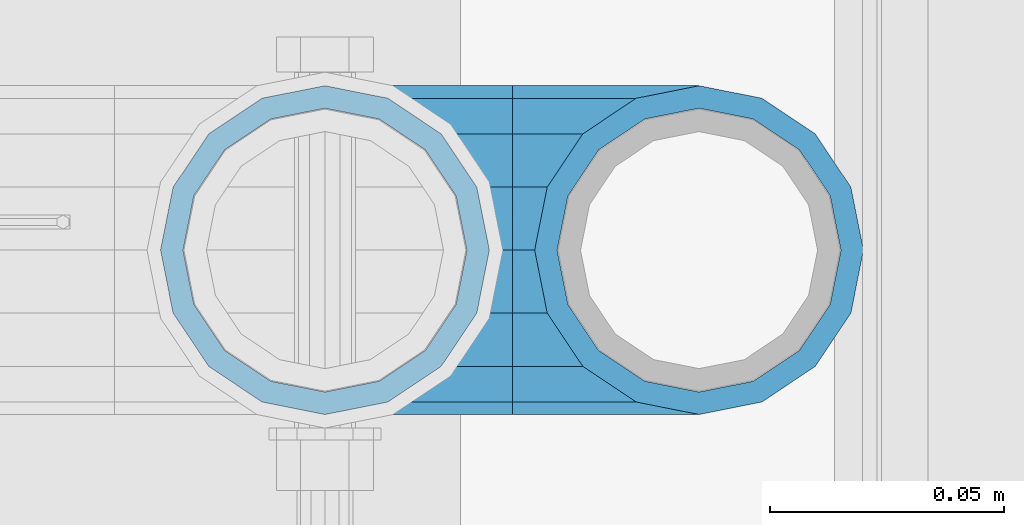
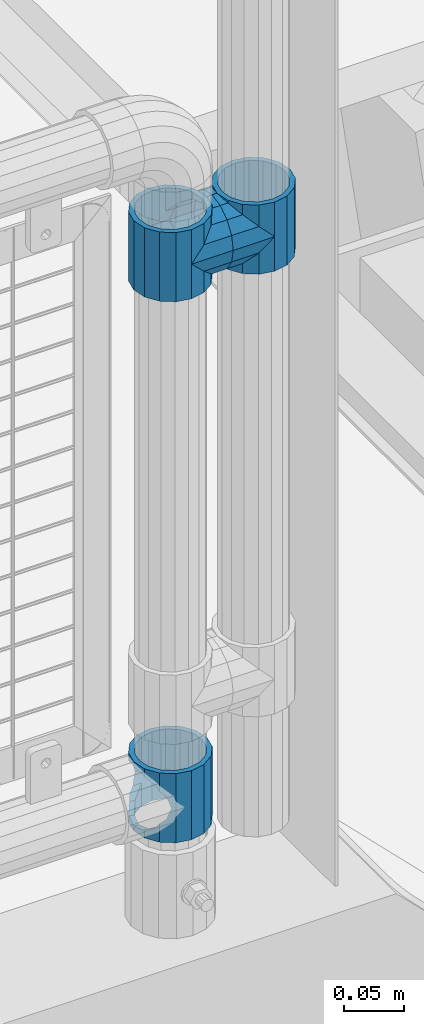
# One storey, part 129 of 193: 5 beams.
"""IFC2X3 building model written with IfcOpenShell, lengths in millimetres."""

from ifc_helpers import new_model, si_unit, frame, origin_with_axes, place, context, subcontext, project, spatial, faceted_brep, material, type_object, element, save


model = new_model("IFC2X3")

# Units and contexts
model_context = context("Model", 3, precision=1e-05, world=origin_with_axes())
body_context = subcontext(model_context, "Body", "Model", "MODEL_VIEW")
ifc_project = project(units=[si_unit("LENGTHUNIT", "METRE", prefix="MILLI"), si_unit("AREAUNIT", "SQUARE_METRE"), si_unit("VOLUMEUNIT", "CUBIC_METRE"), si_unit("MASSUNIT", "GRAM", prefix="KILO"), si_unit("TIMEUNIT", "SECOND"), si_unit("PLANEANGLEUNIT", "RADIAN"), si_unit("SOLIDANGLEUNIT", "STERADIAN"), si_unit("THERMODYNAMICTEMPERATUREUNIT", "DEGREE_CELSIUS"), si_unit("LUMINOUSINTENSITYUNIT", "LUMEN")], contexts=[model_context])

# Site, building, storey
site_placement = place(None, origin_with_axes())
site = spatial("IfcSite", under=ifc_project, at=site_placement, CompositionType="ELEMENT")
building_placement = place(site_placement, origin_with_axes())
building = spatial("IfcBuilding", under=site, at=building_placement, Name="Standard", CompositionType="ELEMENT")
storey_placement = place(building_placement, origin_with_axes())
storey = spatial("IfcBuildingStorey", under=building, at=storey_placement, Name="Undefined", CompositionType="ELEMENT", Elevation=0.0)

# Beams
ifc_material = material(Name="Misc_Undefined")
beam_type = type_object("IfcBeamType", PredefinedType="NOTDEFINED")
beam_1_placement = place(storey_placement, frame((-29019.0, 28664.5, 333.820000000001), z_axis=(1.0, 0.0, 0.0), x_axis=(0.0, 0.0, -1.0)))
element("IfcBeam", 1, at=beam_1_placement, inside=storey, type_object=beam_type, material=ifc_material, context=body_context, shape_type="Brep", body=[
    faceted_brep([(46.7644421722801, 28.0397438117179, -11.614442172282), (46.7644421722801, 28.0397438117179, -20.0882031229849), (51.5310424080006, 24.8548033587067, -24.8548033587067), (56.6106908090114, 21.46069080901, -27.1226768591041), (56.6106908090114, 21.46069080901, -21.46069080901), (61.9623795176744, 13.4513226476338, -32.4743655677703), (63.1897438117172, 11.614442172282, -32.8397438117245), (63.1897438117172, 11.614442172282, -28.0397438117179), (65.4999999999997, 0.0, -35.1500000000015), (65.4999999999997, 0.0, -30.3499999999985), (63.1897438117172, -11.614442172282, -32.8397438117172), (63.1897438117172, -11.614442172282, -28.0397438117179), (61.9623795176767, -13.4513226476338, -32.4743655677703), (56.6106908090114, -21.46069080901, -27.1226768591114), (56.6106908090114, -21.46069080901, -21.46069080901), (51.5310424080006, -24.8548033587067, -24.8548033587067), (46.7644421722801, -28.0397438117179, -20.0882031229812), (46.7644421722801, -28.0397438117179, -11.614442172282), (35.1499999999996, -30.3499999999985, -16.6306603983721), (35.1500000000015, -30.35, 0.0), (23.5355578277191, -28.0397438117179, -20.0882031229812), (23.5355578277191, -28.0397438117179, -11.614442172282), (18.7689575919921, -24.8548033587067, -24.8548033587067), (13.6893091909879, -21.46069080901, -27.1226768591114), (13.6893091909879, -21.46069080901, -21.46069080901), (8.33762048232484, -13.4513226476338, -32.4743655677703), (7.11025618828211, -11.614442172282, -32.8397438117172), (7.11025618828211, -11.614442172282, -28.0397438117179), (4.79999999999961, 0.0, -35.1500000000015), (4.79999999999961, 0.0, -30.3499999999985), (7.11025618828211, 11.614442172282, -32.8397438117245), (7.11025618828211, 11.614442172282, -28.0397438117179), (8.33762048232262, 13.4513226476338, -32.4743655677703), (13.6893091909879, 21.46069080901, -27.1226768591041), (13.6893091909879, 21.46069080901, -21.46069080901), (18.7689575919987, 24.8548033587067, -24.8548033587067), (23.5355578277192, 28.0397438117179, -20.0882031229849), (23.5355578277192, 28.0397438117179, -11.614442172282), (35.1499999999996, 30.3499999999985, -16.6306603983685), (35.1500000000015, 30.35, 0.0), (0.0, 32.4743655677703, -13.4513226476338), (0.0, 35.1500000000015, 0.0), (70.2999999999993, 35.1500000000015, 0.0), (70.2999999999993, 32.4743655677703, -13.4513226476338), (0.0, 32.4743655677703, 13.4513226476338), (70.2999999999993, 32.4743655677703, 13.4513226476338), (0.0, 24.8548033587067, 24.8548033587067), (70.2999999999993, 24.8548033587067, 24.8548033587067), (0.0, 13.4513226476338, 32.4743655677703), (70.2999999999993, 13.4513226476338, 32.4743655677703), (0.0, 0.0, 35.1500000000015), (70.2999999999993, 0.0, 35.1500000000015), (0.0, -13.4513226476338, 32.4743655677703), (70.2999999999993, -13.4513226476338, 32.4743655677703), (0.0, -24.8548033587067, 24.8548033587067), (70.2999999999993, -24.8548033587067, 24.8548033587067), (0.0, -32.4743655677703, 13.4513226476338), (70.2999999999993, -32.4743655677703, 13.4513226476338), (0.0, -35.1500000000015, 0.0), (70.2999999999993, -35.1500000000015, 0.0), (70.2999999999993, -30.3499999999985, 0.0), (70.2999999999993, -28.0397438117179, -11.614442172282), (70.2999999999993, -21.46069080901, -21.46069080901), (70.2999999999993, -11.614442172282, -28.0397438117179), (70.2999999999993, 0.0, -30.3499999999985), (70.2999999999993, 11.614442172282, -28.0397438117179), (70.2999999999993, 21.46069080901, -21.46069080901), (70.2999999999993, 28.0397438117179, -11.614442172282), (0.0, -28.0397438117179, -11.614442172282), (0.0, -30.3499999999985, 0.0), (0.0, -21.46069080901, -21.46069080901), (0.0, -11.614442172282, -28.0397438117179), (0.0, 0.0, -30.3499999999985), (0.0, 11.614442172282, -28.0397438117179), (0.0, 21.46069080901, -21.46069080901), (0.0, 28.0397438117179, -11.614442172282), (0.0, 30.3499999999985, 0.0), (70.2999999999993, 30.3499999999985, 0.0), (0.0, 28.0397438117179, 11.614442172282), (70.2999999999993, 28.0397438117179, 11.614442172282), (0.0, 21.46069080901, 21.46069080901), (70.2999999999993, 21.46069080901, 21.46069080901), (0.0, 11.614442172282, 28.0397438117179), (70.2999999999993, 11.614442172282, 28.0397438117179), (0.0, 0.0, 30.3499999999985), (70.2999999999993, 0.0, 30.3499999999985), (0.0, -11.614442172282, 28.0397438117179), (70.2999999999993, -11.614442172282, 28.0397438117179), (0.0, -21.46069080901, 21.46069080901), (70.2999999999993, -21.46069080901, 21.46069080901), (0.0, -28.0397438117179, 11.614442172282), (70.2999999999993, -28.0397438117179, 11.614442172282), (70.2999999999993, -24.8548033587067, -24.8548033587067), (70.2999999999993, -13.4513226476338, -32.4743655677703), (70.2999999999993, 0.0, -35.1500000000015), (70.2999999999993, 13.4513226476338, -32.4743655677703), (70.2999999999993, 24.8548033587067, -24.8548033587067), (70.2999999999993, -32.4743655677703, -13.4513226476338), (0.0, -32.4743655677703, -13.4513226476338), (0.0, 24.8548033587067, -24.8548033587067), (0.0, 13.4513226476338, -32.4743655677703), (0.0, 0.0, -35.1500000000015), (0.0, -13.4513226476338, -32.4743655677703), (0.0, -24.8548033587067, -24.8548033587067)], [[[0, 1, 2, 3, 4]], [[4, 3, 5, 6, 7]], [[7, 6, 8, 9]], [[9, 8, 10, 11]], [[11, 10, 12, 13, 14]], [[14, 13, 15, 16, 17]], [[17, 16, 18, 19]], [[19, 18, 20, 21]], [[21, 20, 22, 23, 24]], [[24, 23, 25, 26, 27]], [[27, 26, 28, 29]], [[29, 28, 30, 31]], [[31, 30, 32, 33, 34]], [[34, 33, 35, 36, 37]], [[37, 36, 38, 39]], [[39, 38, 1, 0]], [[40, 41, 42, 43]], [[41, 44, 45, 42]], [[44, 46, 47, 45]], [[46, 48, 49, 47]], [[48, 50, 51, 49]], [[50, 52, 53, 51]], [[52, 54, 55, 53]], [[54, 56, 57, 55]], [[56, 58, 59, 57]], [[60, 61, 17, 19]], [[61, 62, 14, 17]], [[62, 63, 11, 14]], [[63, 64, 9, 11]], [[64, 65, 7, 9]], [[65, 66, 4, 7]], [[66, 67, 0, 4]], [[68, 69, 19, 21]], [[70, 68, 21, 24]], [[71, 70, 24, 27]], [[72, 71, 27, 29]], [[73, 72, 29, 31]], [[74, 73, 31, 34]], [[75, 74, 34, 37]], [[76, 75, 37, 39]], [[67, 77, 39, 0]], [[78, 76, 39, 77, 79]], [[80, 78, 79, 81]], [[82, 80, 81, 83]], [[84, 82, 83, 85]], [[86, 84, 85, 87]], [[88, 86, 87, 89]], [[90, 88, 89, 91]], [[19, 69, 90, 91, 60]], [[92, 93, 94, 95, 96, 43, 42, 45, 47, 49, 51, 53, 55, 57, 59, 97], [89, 87, 85, 83, 81, 79, 77, 67, 66, 65, 64, 63, 62, 61, 60, 91]], [[58, 98, 97, 59]], [[56, 54, 52, 50, 48, 46, 44, 41, 40, 99, 100, 101, 102, 103, 98, 58], [68, 70, 71, 72, 73, 74, 75, 76, 78, 80, 82, 84, 86, 88, 90, 69]], [[32, 100, 99, 35, 33]], [[28, 101, 100, 32, 30]], [[102, 101, 28, 26, 25]], [[103, 102, 25, 23, 22]], [[15, 92, 97, 98, 103, 22, 20, 18, 16]], [[12, 93, 92, 15, 13]], [[8, 94, 93, 12, 10]], [[95, 94, 8, 6, 5]], [[96, 95, 5, 3, 2]], [[35, 99, 40, 43, 96, 2, 1, 38, 36]]]),
])
beam_2_placement = place(storey_placement, frame((-29019.0, 28664.5, 848.670000000005), z_axis=(0.0, -1.0, 0.0), x_axis=(1.0, 0.0, 0.0)))
element("IfcBeam", 2, at=beam_2_placement, inside=storey, type_object=beam_type, material=ifc_material, context=body_context, shape_type="Brep", body=[
    faceted_brep([(0.0, 0.0, -35.1500000000015), (13.4513226476338, -13.4513226476329, -32.4743655677703), (13.4513226476338, 13.4513226476329, -32.4743655677703), (32.4743655677703, 32.4743655677717, 13.4513226476338), (32.4743655677703, 26.8123795176754, 13.4513226476338), (27.1226768591041, 21.4606908090117, 21.46069080901), (24.8548033587067, 16.3810424080078, 24.8548033587067), (24.8548033587067, 24.8548033587072, 24.8548033587067), (0.0, 0.0, 35.1500000000015), (13.4513226476338, 13.4513226476329, 32.4743655677703), (13.4513226476338, -13.4513226476329, 32.4743655677703), (20.0882031229849, 11.6144421722805, 28.0397438117179), (16.6306603983685, 0.0, 30.3499999999985), (20.0882031229849, -11.6144421722805, 28.0397438117179), (24.8548033587067, -16.3810424080013, 24.8548033587067), (24.8548033587067, -24.8548033587072, 24.8548033587067), (27.1226768591041, -21.4606908090117, 21.46069080901), (32.4743655677703, -26.8123795176776, 13.4513226476338), (32.4743655677703, -32.4743655677717, 13.4513226476338), (32.8397438117208, -28.0397438117175, 11.614442172282), (35.1500000000015, -30.35, 0.0), (35.1500000000015, -35.15, 0.0), (32.4743655677703, -26.8123795176754, -13.4513226476338), (32.4743655677703, -32.4743655677717, -13.4513226476338), (32.8397438117172, -28.0397438117175, -11.614442172282), (24.8548033587067, -16.3810424080013, -24.8548033587067), (24.8548033587067, -24.8548033587072, -24.8548033587067), (27.1226768591114, -21.4606908090117, -21.46069080901), (20.0882031229849, -11.6144421722805, -28.0397438117179), (16.6306603983721, 0.0, -30.3499999999985), (20.0882031229849, 11.6144421722805, -28.0397438117179), (24.8548033587067, 16.3810424080013, -24.8548033587067), (24.8548033587067, 24.8548033587072, -24.8548033587067), (27.1226768591114, 21.4606908090117, -21.46069080901), (32.4743655677703, 26.8123795176776, -13.4513226476338), (32.4743655677703, 32.4743655677717, -13.4513226476338), (32.8397438117172, 28.0397438117175, -11.614442172282), (35.1500000000015, 30.35, 0.0), (35.1500000000015, 35.15, 0.0), (32.8397438117208, 28.0397438117175, 11.614442172282), (40.1500000000015, -35.15, 0.0), (40.1500000000015, -32.4743655677718, 13.4513226476338), (40.1500000000015, -24.8548033587072, 24.8548033587067), (40.1500000000015, -13.4513226476329, 32.4743655677703), (40.1500000000015, 0.0, 35.1500000000015), (40.1500000000015, 13.4513226476329, 32.4743655677703), (40.1500000000015, 24.8548033587072, 24.8548033587067), (40.1500000000015, 32.4743655677718, 13.4513226476338), (40.1500000000015, 35.15, 0.0), (40.1500000000015, -24.8548033587072, -24.8548033587067), (40.1500000000015, -32.4743655677718, -13.4513226476338), (40.1500000000015, -13.4513226476329, -32.4743655677703), (40.1500000000015, 0.0, -35.1500000000015), (40.1500000000015, 13.4513226476329, -32.4743655677703), (40.1500000000015, 24.8548033587072, -24.8548033587067), (40.1500000000015, 32.4743655677718, -13.4513226476338), (40.1500000000015, -21.4606908090117, 21.46069080901), (40.1500000000015, -11.6144421722805, 28.0397438117179), (40.1500000000015, 0.0, 30.3499999999985), (40.1500000000015, 11.6144421722805, 28.0397438117179), (40.1500000000015, 21.4606908090117, 21.46069080901), (40.1500000000015, 28.0397438117176, 11.614442172282), (40.1500000000015, 30.35, 0.0), (40.1500000000015, 28.0397438117176, -11.614442172282), (40.1500000000015, 21.4606908090117, -21.46069080901), (40.1500000000015, 11.6144421722805, -28.0397438117179), (40.1500000000015, 0.0, -30.3499999999985), (40.1500000000015, -11.6144421722805, -28.0397438117179), (40.1500000000015, -21.4606908090117, -21.46069080901), (40.1500000000015, -28.0397438117176, -11.614442172282), (40.1500000000015, -30.35, 0.0), (40.1500000000015, -28.0397438117176, 11.614442172282)], [[[0, 1, 2]], [[3, 4, 5, 6, 7]], [[8, 9, 10]], [[7, 6, 11, 12, 13, 14, 15, 10, 9]], [[16, 17, 18, 15, 14]], [[19, 20, 21, 18, 17]], [[22, 23, 21, 20, 24]], [[25, 26, 23, 22, 27]], [[2, 1, 26, 25, 28, 29, 30, 31, 32]], [[32, 31, 33, 34, 35]], [[35, 34, 36, 37, 38]], [[38, 37, 39, 4, 3]], [[40, 41, 18, 21]], [[41, 42, 15, 18]], [[42, 43, 10, 15]], [[43, 44, 8, 10]], [[44, 45, 9, 8]], [[45, 46, 7, 9]], [[46, 47, 3, 7]], [[47, 48, 38, 3]], [[49, 50, 23, 26]], [[51, 49, 26, 1]], [[52, 51, 1, 0]], [[53, 52, 0, 2]], [[54, 53, 2, 32]], [[55, 54, 32, 35]], [[48, 55, 35, 38]], [[50, 40, 21, 23]], [[49, 51, 52, 53, 54, 55, 48, 47, 46, 45, 44, 43, 42, 41, 40, 50], [56, 57, 58, 59, 60, 61, 62, 63, 64, 65, 66, 67, 68, 69, 70, 71]], [[63, 62, 37, 36]], [[33, 64, 63, 36, 34]], [[30, 65, 64, 33, 31]], [[66, 65, 30, 29]], [[67, 66, 29, 28]], [[68, 67, 28, 25, 27]], [[69, 68, 27, 22, 24]], [[70, 69, 24, 20]], [[71, 70, 20, 19]], [[16, 56, 71, 19, 17]], [[13, 57, 56, 16, 14]], [[58, 57, 13, 12]], [[59, 58, 12, 11]], [[60, 59, 11, 6, 5]], [[61, 60, 5, 4, 39]], [[62, 61, 39, 37]]]),
])
beam_3_placement = place(storey_placement, frame((-28939.0, 28664.5, 848.670000000005), z_axis=(0.0, 1.0, 0.0), x_axis=(-1.0, 0.0, 0.0)))
element("IfcBeam", 3, at=beam_3_placement, inside=storey, type_object=beam_type, material=ifc_material, context=body_context, shape_type="Brep", body=[
    faceted_brep([(0.0, 0.0, -35.1500000000015), (13.4513226476338, -13.4513226476329, -32.4743655677703), (13.4513226476338, 13.4513226476329, -32.4743655677703), (27.1226768591041, -21.4606908090117, 21.46069080901), (32.4743655677703, -26.8123795176776, 13.4513226476338), (32.4743655677703, -32.4743655677717, 13.4513226476338), (24.8548033587067, -24.8548033587072, 24.8548033587067), (24.8548033587067, -16.3810424080013, 24.8548033587067), (32.8397438117208, -28.0397438117175, 11.614442172282), (35.1500000000015, -30.35, 0.0), (35.1500000000015, -35.15, 0.0), (32.4743655677703, -26.8123795176754, -13.4513226476338), (32.4743655677703, -32.4743655677717, -13.4513226476338), (32.8397438117172, -28.0397438117175, -11.614442172282), (24.8548033587067, -16.3810424080013, -24.8548033587067), (24.8548033587067, -24.8548033587072, -24.8548033587067), (27.1226768591114, -21.4606908090117, -21.46069080901), (20.0882031229849, -11.6144421722805, -28.0397438117179), (16.6306603983721, 0.0, -30.3499999999985), (20.0882031229849, 11.6144421722805, -28.0397438117179), (24.8548033587067, 16.3810424080013, -24.8548033587067), (24.8548033587067, 24.8548033587072, -24.8548033587067), (27.1226768591114, 21.4606908090117, -21.46069080901), (32.4743655677703, 26.8123795176776, -13.4513226476338), (32.4743655677703, 32.4743655677717, -13.4513226476338), (32.8397438117172, 28.0397438117175, -11.614442172282), (35.1500000000015, 30.35, 0.0), (35.1500000000015, 35.15, 0.0), (32.8397438117208, 28.0397438117175, 11.614442172282), (32.4743655677703, 26.8123795176754, 13.4513226476338), (32.4743655677703, 32.4743655677717, 13.4513226476338), (27.1226768591041, 21.4606908090117, 21.46069080901), (24.8548033587067, 16.3810424080078, 24.8548033587067), (24.8548033587067, 24.8548033587072, 24.8548033587067), (0.0, 0.0, 35.1500000000015), (13.4513226476338, 13.4513226476329, 32.4743655677703), (13.4513226476338, -13.4513226476329, 32.4743655677703), (20.0882031229849, 11.6144421722805, 28.0397438117179), (16.6306603983685, 0.0, 30.3499999999985), (20.0882031229849, -11.6144421722805, 28.0397438117179), (40.1500000000015, -35.15, 0.0), (40.1500000000015, -32.4743655677718, 13.4513226476338), (40.1500000000015, -24.8548033587072, 24.8548033587067), (40.1500000000015, -13.4513226476329, 32.4743655677703), (40.1500000000015, 0.0, 35.1500000000015), (40.1500000000015, -24.8548033587072, -24.8548033587067), (40.1500000000015, -32.4743655677718, -13.4513226476338), (40.1500000000015, -13.4513226476329, -32.4743655677703), (40.1500000000015, 0.0, -35.1500000000015), (40.1500000000015, 13.4513226476329, -32.4743655677703), (40.1500000000015, 24.8548033587072, -24.8548033587067), (40.1500000000015, 32.4743655677718, -13.4513226476338), (40.1500000000015, 35.15, 0.0), (40.1500000000015, 32.4743655677718, 13.4513226476338), (40.1500000000015, 24.8548033587072, 24.8548033587067), (40.1500000000015, 13.4513226476329, 32.4743655677703), (40.1500000000015, -21.4606908090117, 21.46069080901), (40.1500000000015, -11.6144421722805, 28.0397438117179), (40.1500000000015, 0.0, 30.3499999999985), (40.1500000000015, 11.6144421722805, 28.0397438117179), (40.1500000000015, 21.4606908090117, 21.46069080901), (40.1500000000015, 28.0397438117176, 11.614442172282), (40.1500000000015, 30.35, 0.0), (40.1500000000015, 28.0397438117176, -11.614442172282), (40.1500000000015, 21.4606908090117, -21.46069080901), (40.1500000000015, 11.6144421722805, -28.0397438117179), (40.1500000000015, 0.0, -30.3499999999985), (40.1500000000015, -11.6144421722805, -28.0397438117179), (40.1500000000015, -21.4606908090117, -21.46069080901), (40.1500000000015, -28.0397438117176, -11.614442172282), (40.1500000000015, -30.35, 0.0), (40.1500000000015, -28.0397438117176, 11.614442172282)], [[[0, 1, 2]], [[3, 4, 5, 6, 7]], [[8, 9, 10, 5, 4]], [[11, 12, 10, 9, 13]], [[14, 15, 12, 11, 16]], [[2, 1, 15, 14, 17, 18, 19, 20, 21]], [[21, 20, 22, 23, 24]], [[24, 23, 25, 26, 27]], [[27, 26, 28, 29, 30]], [[30, 29, 31, 32, 33]], [[34, 35, 36]], [[33, 32, 37, 38, 39, 7, 6, 36, 35]], [[40, 41, 5, 10]], [[41, 42, 6, 5]], [[42, 43, 36, 6]], [[43, 44, 34, 36]], [[45, 46, 12, 15]], [[47, 45, 15, 1]], [[48, 47, 1, 0]], [[49, 48, 0, 2]], [[50, 49, 2, 21]], [[51, 50, 21, 24]], [[52, 51, 24, 27]], [[53, 52, 27, 30]], [[54, 53, 30, 33]], [[55, 54, 33, 35]], [[44, 55, 35, 34]], [[46, 40, 10, 12]], [[45, 47, 48, 49, 50, 51, 52, 53, 54, 55, 44, 43, 42, 41, 40, 46], [56, 57, 58, 59, 60, 61, 62, 63, 64, 65, 66, 67, 68, 69, 70, 71]], [[59, 58, 38, 37]], [[60, 59, 37, 32, 31]], [[61, 60, 31, 29, 28]], [[62, 61, 28, 26]], [[63, 62, 26, 25]], [[22, 64, 63, 25, 23]], [[19, 65, 64, 22, 20]], [[66, 65, 19, 18]], [[67, 66, 18, 17]], [[68, 67, 17, 14, 16]], [[69, 68, 16, 11, 13]], [[70, 69, 13, 9]], [[71, 70, 9, 8]], [[3, 56, 71, 8, 4]], [[39, 57, 56, 3, 7]], [[58, 57, 39, 38]]]),
])
beam_4_placement = place(storey_placement, frame((-29019.0, 28664.5, 883.820000000004), z_axis=(-1.0, 0.0, 0.0), x_axis=(0.0, 0.0, -1.0)))
element("IfcBeam", 4, at=beam_4_placement, inside=storey, type_object=beam_type, material=ifc_material, context=body_context, shape_type="Brep", body=[
    faceted_brep([(13.6893091909879, -21.46069080901, -21.46069080901), (13.6893091909879, -21.46069080901, -27.1226768591114), (8.33762048232484, -13.4513226476338, -32.4743655677703), (7.11025618828211, -11.614442172282, -32.8397438117172), (7.11025618828211, -11.614442172282, -28.0397438117179), (23.5355578277191, -28.0397438117179, -11.614442172282), (23.5355578277191, -28.0397438117179, -20.0882031229812), (18.7689575919921, -24.8548033587067, -24.8548033587067), (35.1500000000015, -30.35, 0.0), (35.1499999999996, -30.3499999999985, -16.6306603983721), (46.7644421722801, -28.0397438117179, -11.614442172282), (46.7644421722801, -28.0397438117179, -20.0882031229812), (56.6106908090114, -21.46069080901, -21.46069080901), (56.6106908090114, -21.46069080901, -27.1226768591114), (51.5310424080006, -24.8548033587067, -24.8548033587067), (63.1897438117172, -11.614442172282, -28.0397438117179), (63.1897438117172, -11.614442172282, -32.8397438117172), (61.9623795176767, -13.4513226476338, -32.4743655677703), (65.4999999999997, 0.0, -30.3499999999985), (65.4999999999997, 0.0, -35.1500000000015), (63.1897438117172, 11.614442172282, -28.0397438117179), (63.1897438117172, 11.614442172282, -32.8397438117245), (56.6106908090114, 21.46069080901, -21.46069080901), (56.6106908090114, 21.46069080901, -27.1226768591041), (61.9623795176744, 13.4513226476338, -32.4743655677703), (46.7644421722801, 28.0397438117179, -11.614442172282), (46.7644421722801, 28.0397438117179, -20.0882031229849), (51.5310424080006, 24.8548033587067, -24.8548033587067), (35.1500000000015, 30.35, 0.0), (35.1499999999996, 30.3499999999985, -16.6306603983685), (23.5355578277192, 28.0397438117179, -11.614442172282), (23.5355578277192, 28.0397438117179, -20.0882031229849), (13.6893091909879, 21.46069080901, -21.46069080901), (13.6893091909879, 21.46069080901, -27.1226768591041), (18.7689575919987, 24.8548033587067, -24.8548033587067), (7.11025618828211, 11.614442172282, -28.0397438117179), (7.11025618828211, 11.614442172282, -32.8397438117245), (8.33762048232262, 13.4513226476338, -32.4743655677703), (4.79999999999961, 0.0, -30.3499999999985), (4.79999999999961, 0.0, -35.1500000000015), (0.0, 21.46069080901, 21.46069080901), (0.0, 28.0397438117179, 11.614442172282), (70.2999999999993, 28.0397438117179, 11.614442172282), (70.2999999999993, 21.46069080901, 21.46069080901), (0.0, 11.614442172282, 28.0397438117179), (70.2999999999993, 11.614442172282, 28.0397438117179), (0.0, 0.0, 30.3499999999985), (70.2999999999993, 0.0, 30.3499999999985), (0.0, -11.614442172282, 28.0397438117179), (70.2999999999993, -11.614442172282, 28.0397438117179), (0.0, -21.46069080901, 21.46069080901), (70.2999999999993, -21.46069080901, 21.46069080901), (0.0, -28.0397438117179, 11.614442172282), (70.2999999999993, -28.0397438117179, 11.614442172282), (0.0, -24.8548033587067, -24.8548033587067), (0.0, -13.4513226476338, -32.4743655677703), (0.0, 0.0, -35.1500000000015), (0.0, -32.4743655677703, 13.4513226476338), (0.0, -35.1500000000015, 0.0), (70.2999999999993, -35.1500000000015, 0.0), (70.2999999999993, -32.4743655677703, 13.4513226476338), (0.0, -24.8548033587067, 24.8548033587067), (70.2999999999993, -24.8548033587067, 24.8548033587067), (0.0, -13.4513226476338, 32.4743655677703), (70.2999999999993, -13.4513226476338, 32.4743655677703), (0.0, 0.0, 35.1500000000015), (70.2999999999993, 0.0, 35.1500000000015), (0.0, 13.4513226476338, 32.4743655677703), (70.2999999999993, 13.4513226476338, 32.4743655677703), (0.0, 24.8548033587067, 24.8548033587067), (70.2999999999993, 24.8548033587067, 24.8548033587067), (0.0, 32.4743655677703, 13.4513226476338), (70.2999999999993, 32.4743655677703, 13.4513226476338), (0.0, 35.1500000000015, 0.0), (70.2999999999993, 35.1500000000015, 0.0), (0.0, 32.4743655677703, -13.4513226476338), (70.2999999999993, 32.4743655677703, -13.4513226476338), (70.2999999999993, -13.4513226476338, -32.4743655677703), (70.2999999999993, -24.8548033587067, -24.8548033587067), (70.2999999999993, 0.0, -35.1500000000015), (70.2999999999993, 13.4513226476338, -32.4743655677703), (70.2999999999993, 24.8548033587067, -24.8548033587067), (0.0, 24.8548033587067, -24.8548033587067), (0.0, 13.4513226476338, -32.4743655677703), (70.2999999999993, -32.4743655677703, -13.4513226476338), (0.0, -32.4743655677703, -13.4513226476338), (0.0, -28.0397438117179, -11.614442172282), (0.0, -21.46069080901, -21.46069080901), (0.0, -11.614442172282, -28.0397438117179), (0.0, 0.0, -30.3499999999985), (0.0, 11.614442172282, -28.0397438117179), (0.0, 21.46069080901, -21.46069080901), (0.0, 28.0397438117179, -11.614442172282), (0.0, 30.3499999999985, 0.0), (0.0, -30.3499999999985, 0.0), (70.2999999999993, 30.3499999999985, 0.0), (70.2999999999993, 28.0397438117179, -11.614442172282), (70.2999999999993, 21.46069080901, -21.46069080901), (70.2999999999993, 11.614442172282, -28.0397438117179), (70.2999999999993, 0.0, -30.3499999999985), (70.2999999999993, -11.614442172282, -28.0397438117179), (70.2999999999993, -21.46069080901, -21.46069080901), (70.2999999999993, -28.0397438117179, -11.614442172282), (70.2999999999993, -30.3499999999985, 0.0)], [[[0, 1, 2, 3, 4]], [[5, 6, 7, 1, 0]], [[8, 9, 6, 5]], [[10, 11, 9, 8]], [[12, 13, 14, 11, 10]], [[15, 16, 17, 13, 12]], [[18, 19, 16, 15]], [[20, 21, 19, 18]], [[22, 23, 24, 21, 20]], [[25, 26, 27, 23, 22]], [[28, 29, 26, 25]], [[30, 31, 29, 28]], [[32, 33, 34, 31, 30]], [[35, 36, 37, 33, 32]], [[38, 39, 36, 35]], [[4, 3, 39, 38]], [[40, 41, 42, 43]], [[44, 40, 43, 45]], [[46, 44, 45, 47]], [[48, 46, 47, 49]], [[50, 48, 49, 51]], [[52, 50, 51, 53]], [[54, 55, 2, 1, 7]], [[55, 56, 39, 3, 2]], [[57, 58, 59, 60]], [[61, 57, 60, 62]], [[63, 61, 62, 64]], [[65, 63, 64, 66]], [[67, 65, 66, 68]], [[69, 67, 68, 70]], [[71, 69, 70, 72]], [[73, 71, 72, 74]], [[75, 73, 74, 76]], [[17, 77, 78, 14, 13]], [[19, 79, 77, 17, 16]], [[80, 79, 19, 21, 24]], [[81, 80, 24, 23, 27]], [[34, 82, 75, 76, 81, 27, 26, 29, 31]], [[37, 83, 82, 34, 33]], [[39, 56, 83, 37, 36]], [[14, 78, 84, 85, 54, 7, 6, 9, 11]], [[58, 85, 84, 59]], [[57, 61, 63, 65, 67, 69, 71, 73, 75, 82, 83, 56, 55, 54, 85, 58], [86, 87, 88, 89, 90, 91, 92, 93, 41, 40, 44, 46, 48, 50, 52, 94]], [[90, 89, 38, 35]], [[91, 90, 35, 32]], [[92, 91, 32, 30]], [[93, 92, 30, 28]], [[41, 93, 28, 95, 42]], [[96, 95, 28, 25]], [[97, 96, 25, 22]], [[98, 97, 22, 20]], [[99, 98, 20, 18]], [[100, 99, 18, 15]], [[101, 100, 15, 12]], [[102, 101, 12, 10]], [[103, 102, 10, 8]], [[78, 77, 79, 80, 81, 76, 74, 72, 70, 68, 66, 64, 62, 60, 59, 84], [51, 49, 47, 45, 43, 42, 95, 96, 97, 98, 99, 100, 101, 102, 103, 53]], [[8, 94, 52, 53, 103]], [[86, 94, 8, 5]], [[87, 86, 5, 0]], [[88, 87, 0, 4]], [[89, 88, 4, 38]]]),
])
beam_5_placement = place(storey_placement, frame((-28939.0, 28664.5, 883.820000000004), z_axis=(1.0, 0.0, 0.0), x_axis=(0.0, 0.0, -1.0)))
element("IfcBeam", 5, at=beam_5_placement, inside=storey, type_object=beam_type, material=ifc_material, context=body_context, shape_type="Brep", body=[
    faceted_brep([(46.7644421722801, 28.0397438117179, -11.614442172282), (46.7644421722801, 28.0397438117179, -20.0882031229849), (51.5310424080006, 24.8548033587067, -24.8548033587067), (56.6106908090114, 21.46069080901, -27.1226768591041), (56.6106908090114, 21.46069080901, -21.46069080901), (61.9623795176744, 13.4513226476338, -32.4743655677703), (63.1897438117172, 11.614442172282, -32.8397438117245), (63.1897438117172, 11.614442172282, -28.0397438117179), (65.4999999999997, 0.0, -35.1500000000015), (65.4999999999997, 0.0, -30.3499999999985), (63.1897438117172, -11.614442172282, -32.8397438117172), (63.1897438117172, -11.614442172282, -28.0397438117179), (61.9623795176767, -13.4513226476338, -32.4743655677703), (56.6106908090114, -21.46069080901, -27.1226768591114), (56.6106908090114, -21.46069080901, -21.46069080901), (51.5310424080006, -24.8548033587067, -24.8548033587067), (46.7644421722801, -28.0397438117179, -20.0882031229812), (46.7644421722801, -28.0397438117179, -11.614442172282), (35.1499999999996, -30.3499999999985, -16.6306603983721), (35.1500000000015, -30.35, 0.0), (23.5355578277191, -28.0397438117179, -20.0882031229812), (23.5355578277191, -28.0397438117179, -11.614442172282), (18.7689575919921, -24.8548033587067, -24.8548033587067), (13.6893091909879, -21.46069080901, -27.1226768591114), (13.6893091909879, -21.46069080901, -21.46069080901), (8.33762048232484, -13.4513226476338, -32.4743655677703), (7.11025618828211, -11.614442172282, -32.8397438117172), (7.11025618828211, -11.614442172282, -28.0397438117179), (4.79999999999961, 0.0, -35.1500000000015), (4.79999999999961, 0.0, -30.3499999999985), (7.11025618828211, 11.614442172282, -32.8397438117245), (7.11025618828211, 11.614442172282, -28.0397438117179), (8.33762048232262, 13.4513226476338, -32.4743655677703), (13.6893091909879, 21.46069080901, -27.1226768591041), (13.6893091909879, 21.46069080901, -21.46069080901), (18.7689575919987, 24.8548033587067, -24.8548033587067), (23.5355578277192, 28.0397438117179, -20.0882031229849), (23.5355578277192, 28.0397438117179, -11.614442172282), (35.1499999999996, 30.3499999999985, -16.6306603983685), (35.1500000000015, 30.35, 0.0), (0.0, 32.4743655677703, -13.4513226476338), (0.0, 35.1500000000015, 0.0), (70.2999999999993, 35.1500000000015, 0.0), (70.2999999999993, 32.4743655677703, -13.4513226476338), (0.0, 32.4743655677703, 13.4513226476338), (70.2999999999993, 32.4743655677703, 13.4513226476338), (0.0, 24.8548033587067, 24.8548033587067), (70.2999999999993, 24.8548033587067, 24.8548033587067), (0.0, 13.4513226476338, 32.4743655677703), (70.2999999999993, 13.4513226476338, 32.4743655677703), (0.0, 0.0, 35.1500000000015), (70.2999999999993, 0.0, 35.1500000000015), (0.0, -13.4513226476338, 32.4743655677703), (70.2999999999993, -13.4513226476338, 32.4743655677703), (0.0, -24.8548033587067, 24.8548033587067), (70.2999999999993, -24.8548033587067, 24.8548033587067), (0.0, -32.4743655677703, 13.4513226476338), (70.2999999999993, -32.4743655677703, 13.4513226476338), (0.0, -35.1500000000015, 0.0), (70.2999999999993, -35.1500000000015, 0.0), (70.2999999999993, -30.3499999999985, 0.0), (70.2999999999993, -28.0397438117179, -11.614442172282), (70.2999999999993, -21.46069080901, -21.46069080901), (70.2999999999993, -11.614442172282, -28.0397438117179), (70.2999999999993, 0.0, -30.3499999999985), (70.2999999999993, 11.614442172282, -28.0397438117179), (70.2999999999993, 21.46069080901, -21.46069080901), (70.2999999999993, 28.0397438117179, -11.614442172282), (0.0, -28.0397438117179, -11.614442172282), (0.0, -30.3499999999985, 0.0), (0.0, -21.46069080901, -21.46069080901), (0.0, -11.614442172282, -28.0397438117179), (0.0, 0.0, -30.3499999999985), (0.0, 11.614442172282, -28.0397438117179), (0.0, 21.46069080901, -21.46069080901), (0.0, 28.0397438117179, -11.614442172282), (0.0, 30.3499999999985, 0.0), (70.2999999999993, 30.3499999999985, 0.0), (0.0, 28.0397438117179, 11.614442172282), (70.2999999999993, 28.0397438117179, 11.614442172282), (0.0, 21.46069080901, 21.46069080901), (70.2999999999993, 21.46069080901, 21.46069080901), (0.0, 11.614442172282, 28.0397438117179), (70.2999999999993, 11.614442172282, 28.0397438117179), (0.0, 0.0, 30.3499999999985), (70.2999999999993, 0.0, 30.3499999999985), (0.0, -11.614442172282, 28.0397438117179), (70.2999999999993, -11.614442172282, 28.0397438117179), (0.0, -21.46069080901, 21.46069080901), (70.2999999999993, -21.46069080901, 21.46069080901), (0.0, -28.0397438117179, 11.614442172282), (70.2999999999993, -28.0397438117179, 11.614442172282), (70.2999999999993, -24.8548033587067, -24.8548033587067), (70.2999999999993, -13.4513226476338, -32.4743655677703), (70.2999999999993, 0.0, -35.1500000000015), (70.2999999999993, 13.4513226476338, -32.4743655677703), (70.2999999999993, 24.8548033587067, -24.8548033587067), (70.2999999999993, -32.4743655677703, -13.4513226476338), (0.0, -32.4743655677703, -13.4513226476338), (0.0, 24.8548033587067, -24.8548033587067), (0.0, 13.4513226476338, -32.4743655677703), (0.0, 0.0, -35.1500000000015), (0.0, -13.4513226476338, -32.4743655677703), (0.0, -24.8548033587067, -24.8548033587067)], [[[0, 1, 2, 3, 4]], [[4, 3, 5, 6, 7]], [[7, 6, 8, 9]], [[9, 8, 10, 11]], [[11, 10, 12, 13, 14]], [[14, 13, 15, 16, 17]], [[17, 16, 18, 19]], [[19, 18, 20, 21]], [[21, 20, 22, 23, 24]], [[24, 23, 25, 26, 27]], [[27, 26, 28, 29]], [[29, 28, 30, 31]], [[31, 30, 32, 33, 34]], [[34, 33, 35, 36, 37]], [[37, 36, 38, 39]], [[39, 38, 1, 0]], [[40, 41, 42, 43]], [[41, 44, 45, 42]], [[44, 46, 47, 45]], [[46, 48, 49, 47]], [[48, 50, 51, 49]], [[50, 52, 53, 51]], [[52, 54, 55, 53]], [[54, 56, 57, 55]], [[56, 58, 59, 57]], [[60, 61, 17, 19]], [[61, 62, 14, 17]], [[62, 63, 11, 14]], [[63, 64, 9, 11]], [[64, 65, 7, 9]], [[65, 66, 4, 7]], [[66, 67, 0, 4]], [[68, 69, 19, 21]], [[70, 68, 21, 24]], [[71, 70, 24, 27]], [[72, 71, 27, 29]], [[73, 72, 29, 31]], [[74, 73, 31, 34]], [[75, 74, 34, 37]], [[76, 75, 37, 39]], [[67, 77, 39, 0]], [[78, 76, 39, 77, 79]], [[80, 78, 79, 81]], [[82, 80, 81, 83]], [[84, 82, 83, 85]], [[86, 84, 85, 87]], [[88, 86, 87, 89]], [[90, 88, 89, 91]], [[19, 69, 90, 91, 60]], [[92, 93, 94, 95, 96, 43, 42, 45, 47, 49, 51, 53, 55, 57, 59, 97], [89, 87, 85, 83, 81, 79, 77, 67, 66, 65, 64, 63, 62, 61, 60, 91]], [[58, 98, 97, 59]], [[56, 54, 52, 50, 48, 46, 44, 41, 40, 99, 100, 101, 102, 103, 98, 58], [68, 70, 71, 72, 73, 74, 75, 76, 78, 80, 82, 84, 86, 88, 90, 69]], [[32, 100, 99, 35, 33]], [[28, 101, 100, 32, 30]], [[102, 101, 28, 26, 25]], [[103, 102, 25, 23, 22]], [[15, 92, 97, 98, 103, 22, 20, 18, 16]], [[12, 93, 92, 15, 13]], [[8, 94, 93, 12, 10]], [[95, 94, 8, 6, 5]], [[96, 95, 5, 3, 2]], [[35, 99, 40, 43, 96, 2, 1, 38, 36]]]),
])

save(model, "model.ifc")
